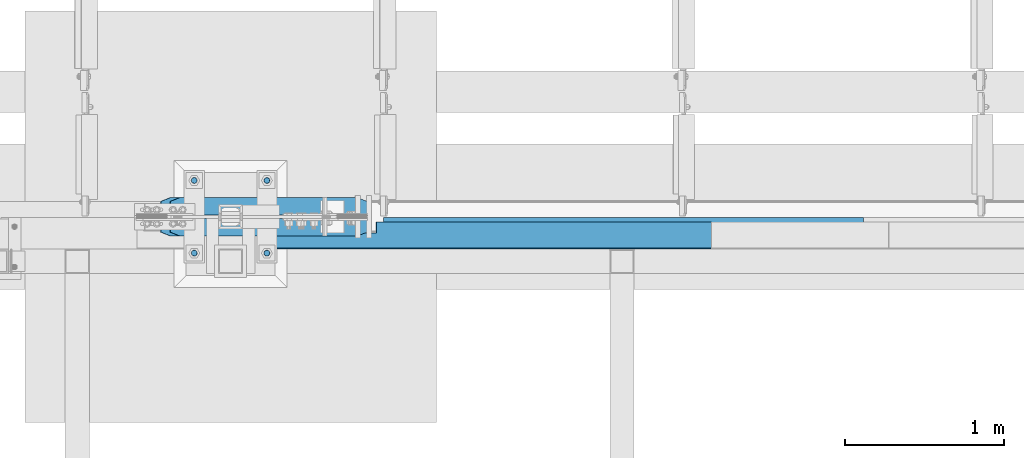
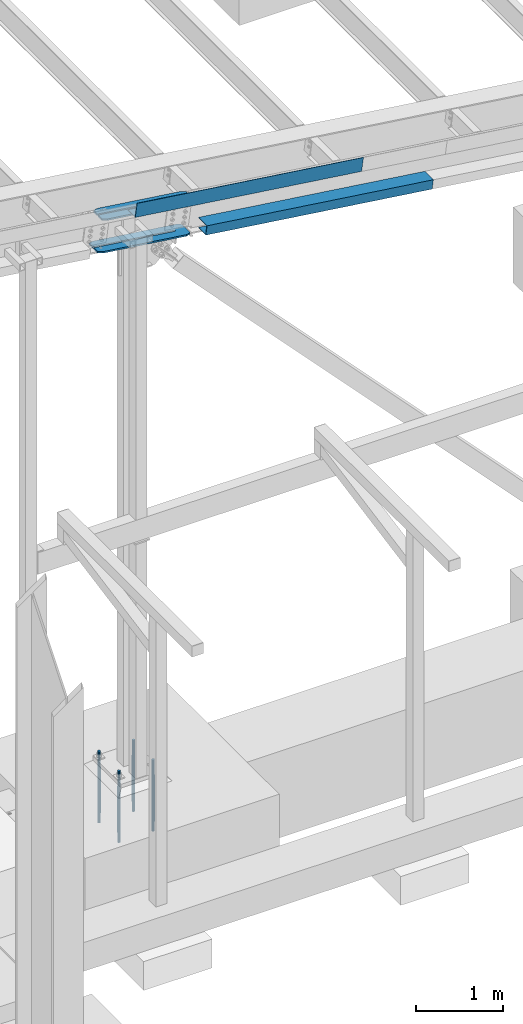
# One storey, part 744 of 1179: 8 beams, 3 elements without a shape of their own.
"""IFC2X3 building model written with IfcOpenShell, lengths in millimetres."""

from ifc_helpers import new_model, si_unit, frame, origin_with_axes, place, context, subcontext, project, spatial, faceted_brep, material, type_object, element, aggregate, save


model = new_model("IFC2X3")

# Units and contexts
model_context = context("Model", 3, precision=1e-05, world=origin_with_axes())
body_context = subcontext(model_context, "Body", "Model", "MODEL_VIEW")
ifc_project = project(units=[si_unit("LENGTHUNIT", "METRE", prefix="MILLI"), si_unit("AREAUNIT", "SQUARE_METRE"), si_unit("VOLUMEUNIT", "CUBIC_METRE"), si_unit("MASSUNIT", "GRAM", prefix="KILO"), si_unit("TIMEUNIT", "SECOND"), si_unit("PLANEANGLEUNIT", "RADIAN"), si_unit("SOLIDANGLEUNIT", "STERADIAN"), si_unit("THERMODYNAMICTEMPERATUREUNIT", "DEGREE_CELSIUS"), si_unit("LUMINOUSINTENSITYUNIT", "LUMEN")], contexts=[model_context])

# Site, building, storey
site_placement = place(None, origin_with_axes())
site = spatial("IfcSite", under=ifc_project, at=site_placement, CompositionType="ELEMENT")
building_placement = place(site_placement, origin_with_axes())
building = spatial("IfcBuilding", under=site, at=building_placement, Name="Undefined", CompositionType="ELEMENT")
storey_placement = place(building_placement, origin_with_axes())
storey = spatial("IfcBuildingStorey", under=building, at=storey_placement, Name="Undefined", CompositionType="ELEMENT", Elevation=0.0)

# Assembly, beams
assembly_1_placement = place(storey_placement, origin_with_axes())
assembly_1 = element("IfcElementAssembly", 1, at=assembly_1_placement, inside=storey, Name="BEAM", AssemblyPlace="NOTDEFINED", PredefinedType="RIGID_FRAME")
ifc_material_1 = material(Name="STEEL/A36")
beam_type_1 = type_object("IfcBeamType", PredefinedType="NOTDEFINED")
beam_1_placement = place(assembly_1_placement, frame((29302.4965897463, 4448.17500000529, 7554.44310047131), z_axis=(0.99100656965293, 0.0, -0.133813223953134), x_axis=(-0.133813222971046, 0.0, -0.991006569785539)))
beam_1 = element("IfcBeam", 2, at=beam_1_placement, type_object=beam_type_1, material=ifc_material_1, Name="BENT_PLATE", context=body_context, shape_type="Brep", body=[
    faceted_brep([(190.499999995369, 166.687500010301, -703.547262437609), (184.149999995367, 166.687500010301, -703.547262437613), (184.149999995199, 96.8374997306582, -703.547262437052), (190.499999995202, 96.8374997306582, -703.547262437067), (190.4999999953, 96.8374997503342, -603.862211291878), (184.149999995298, 96.8374997503342, -603.862211291867), (184.149999995439, 166.687500010349, -603.862211292424), (190.499999995443, 166.687500010349, -603.862211292424), (0.0, -3.17499999999927, -1524.0), (6.00266503170133e-10, -3.17499999922438, 1524.00000000052), (6.00266503170133e-10, 3.17500000077416, 1524.00000000052), (0.0, 3.17499999999927, -1524.0), (184.149999997837, 3.17500000000018, 1524.00000000004), (184.149999993959, 3.17500000000018, -1524.00000000062), (190.499999993961, -3.17500000000018, -1524.00000000063), (184.149999994715, 166.687499981327, -1524.00000000071), (190.499999994716, 166.687499981327, -1524.00000000072), (190.499999997839, -3.17500000000018, 1524.00000000003), (190.499999997002, 166.687500011378, 1523.99999999994), (184.149999997, 166.687500011378, 1523.99999999996)], [[[0, 1, 2, 3]], [[4, 5, 6, 7]], [[3, 2, 5, 4]], [[8, 9, 10, 11]], [[11, 10, 12, 13]], [[14, 8, 11, 13, 15, 16]], [[9, 8, 14, 17]], [[12, 10, 9, 17, 18, 19]], [[19, 18, 7, 6]], [[1, 15, 13, 12, 19, 6, 5, 2]], [[16, 15, 1, 0]], [[18, 17, 14, 16, 0, 3, 4, 7]]]),
])
beam_type_2 = type_object("IfcBeamType", PredefinedType="NOTDEFINED")
beam_2_placement = place(assembly_1_placement, frame((30235.061825248, 4642.64374999283, 6909.50331876021), z_axis=(-0.99100656978554, 0.0, 0.133813222971043), x_axis=(0.0, -1.0, 0.0)))
beam_2 = element("IfcBeam", 3, at=beam_2_placement, type_object=beam_type_2, material=ifc_material_1, Name="BENT_PLATE", context=body_context, shape_type="Brep", body=[
    faceted_brep([(0.0, -3.17499999999927, -1524.0), (6.00266503170133e-10, -3.17499999922438, 1524.00000000052), (6.00266503170133e-10, 3.17500000077416, 1524.00000000052), (0.0, 3.17499999999927, -1524.0), (197.643749996568, 3.17499999764368, 1524.00000000029), (197.64374999733, 3.17499999680149, -1524.00000000037), (191.29374999733, -3.17500000311156, -1524.00000000037), (191.293749996567, -3.17500000226937, 1524.0000000003), (197.643749997295, -123.825000009543, 1524.00000000049), (197.643749996602, -123.825000012654, -1524.00000000017), (191.293749996602, -117.47500001367, -1524.00000000018), (191.293749997295, -117.47500001056, 1524.00000000048), (27.7812499864749, -123.825000037206, 1524.00000000058), (27.7812499848405, -123.825000039436, -1524.00000000008), (27.7812499854572, -117.475000037206, 1524.00000000057), (27.7812499838228, -117.475000039432, -1524.00000000009)], [[[0, 1, 2, 3]], [[3, 2, 4, 5]], [[1, 0, 6, 7]], [[5, 4, 8, 9]], [[7, 6, 10, 11]], [[9, 8, 12, 13]], [[8, 4, 2, 1, 7, 11, 14, 12]], [[11, 10, 15, 14]], [[10, 6, 0, 3, 5, 9, 13, 15]], [[14, 15, 13, 12]]]),
])
aggregate(assembly_1, [beam_1, beam_2])

assembly_2_placement = place(storey_placement, origin_with_axes())
assembly_2 = element("IfcElementAssembly", 4, at=assembly_2_placement, inside=storey, Name="COLUMN", AssemblyPlace="NOTDEFINED", PredefinedType="RIGID_FRAME")
ifc_material_2 = material(Name="STEEL/A572-GR.50")
beam_type_3 = type_object("IfcBeamType", PredefinedType="NOTDEFINED")
beam_3_placement = place(assembly_2_placement, frame((27322.974220071, 4648.2000010376, 7169.75722502091), z_axis=(0.0, -1.0, 0.0), x_axis=(0.99100656965293, 0.0, -0.133813223953134)))
beam_3 = element("IfcBeam", 5, at=beam_3_placement, type_object=beam_type_3, material=ifc_material_2, Name="PLATE", context=body_context, shape_type="Brep", body=[
    faceted_brep([(63.5000000000036, -11.1125000000211, -122.2375), (-1.09139364212751e-11, -11.1125000000029, -96.8374999999996), (1.81898940354586e-11, 11.1125000000047, -96.8374999999996), (63.5000000000291, 11.1124999999884, -122.2375), (63.5000000000291, 11.1124999999884, 122.2375), (1.81898940354586e-11, 11.1125000000047, 96.8374999999996), (-1.09139364212751e-11, -11.1125000000029, 96.8374999999996), (63.5000000000036, -11.1125000000211, 122.2375), (1247.75782309306, -11.1125000003485, -96.8374999999996), (1184.25782309304, -11.1125000003303, -122.2375), (1184.25782309307, 11.1124999996773, -122.2375), (1247.75782309308, 11.1124999996609, -96.8374999999996), (1247.75782309308, 11.1124999996609, 96.8374999999996), (1184.25782309307, 11.1124999996773, 122.2375), (1184.25782309304, -11.1125000003303, 122.2375), (1247.75782309306, -11.1125000003485, 96.8374999999996), (-1.09139364212751e-11, -11.1125000000029, 11.1125010375927), (1.81898940354586e-11, 11.1125000000047, 11.1125010375927), (1093.77032170487, 11.1124999997028, 11.1125010375927), (1093.77018739046, -11.1125000003049, 11.1125010375927), (1098.02289142009, 11.112499999701, 10.2666123281051), (1098.02275710569, -11.1125000003067, 10.2666123281051), (1101.62804594581, 11.112499999701, 7.85772508766331), (1101.62791163141, -11.1125000003085, 7.85772508766331), (1104.0369331863, 11.112499999701, 4.25257056200553), (1104.0367988719, -11.1125000003085, 4.25257056200553), (1093.77018739046, -11.1125000003049, -11.1124989624059), (1093.77032170487, 11.1124999997028, -11.1124989624059), (1.81898940354586e-11, 11.1125000000047, -11.1124989624059), (-1.09139364212751e-11, -11.1125000000029, -11.1124989624059), (1098.02275710569, -11.1125000003067, -10.2666102529183), (1098.02289142009, 11.112499999701, -10.2666102529183), (1101.62791163141, -11.1125000003085, -7.85772301247653), (1101.62804594581, 11.112499999701, -7.85772301247653), (1104.0367988719, -11.1125000003085, -4.25256848681875), (1104.0369331863, 11.112499999701, -4.25256848681875), (1104.8826875814, -11.1125000003085, 8.46857801661827e-07), (1104.8828218958, 11.1124999996991, 8.46857801661827e-07)], [[[0, 1, 2, 3]], [[4, 5, 6, 7]], [[8, 9, 10, 11]], [[12, 13, 14, 15]], [[16, 17, 18, 19]], [[19, 18, 20, 21]], [[21, 20, 22, 23]], [[23, 22, 24, 25]], [[26, 27, 28, 29]], [[30, 31, 27, 26]], [[32, 33, 31, 30]], [[34, 35, 33, 32]], [[36, 37, 35, 34]], [[25, 24, 37, 36]], [[14, 13, 4, 7]], [[12, 15, 8, 11]], [[10, 9, 0, 3]], [[29, 28, 2, 1]], [[28, 27, 31, 33, 35, 37, 24, 22, 20, 18, 17, 5, 4, 13, 12, 11, 10, 3, 2]], [[17, 16, 6, 5]], [[9, 8, 15, 14, 7, 6, 16, 19, 21, 23, 25, 36, 34, 32, 30, 26, 29, 1, 0]]]),
])
beam_4_placement = place(assembly_2_placement, frame((27382.4541981187, 4648.2000010376, 7610.25964523436), z_axis=(0.0, -1.0, 0.0), x_axis=(0.99100656965293, 0.0, -0.133813223953134)))
beam_4 = element("IfcBeam", 6, at=beam_4_placement, type_object=beam_type_3, material=ifc_material_2, Name="PLATE", context=body_context, shape_type="Brep", body=[
    faceted_brep([(63.5000000000036, -11.1125000000211, -122.2375), (-1.09139364212751e-11, -11.1125000000029, -96.8374999999996), (1.81898940354586e-11, 11.1125000000047, -96.8374999999996), (63.5000000000291, 11.1124999999884, -122.2375), (63.5000000000291, 11.1124999999884, 122.2375), (1.81898940354586e-11, 11.1125000000047, 96.8374999999996), (-1.09139364212751e-11, -11.1125000000029, 96.8374999999996), (63.5000000000036, -11.1125000000211, 122.2375), (1247.75782309306, -11.1125000003485, -96.8374999999996), (1184.25782309304, -11.1125000003303, -122.2375), (1184.25782309307, 11.1124999996773, -122.2375), (1247.75782309308, 11.1124999996609, -96.8374999999996), (1247.75782309308, 11.1124999996609, 96.8374999999996), (1184.25782309307, 11.1124999996773, 122.2375), (1184.25782309304, -11.1125000003303, 122.2375), (1247.75782309306, -11.1125000003485, 96.8374999999996), (-1.09139364212751e-11, -11.1125000000029, 11.1125010375927), (1.81898940354586e-11, 11.1125000000047, 11.1125010375927), (1093.77032170487, 11.1124999997028, 11.1125010375927), (1093.77018739046, -11.1125000003049, 11.1125010375927), (1098.02289142009, 11.112499999701, 10.2666123281051), (1098.02275710569, -11.1125000003067, 10.2666123281051), (1101.62804594581, 11.112499999701, 7.85772508766331), (1101.62791163141, -11.1125000003085, 7.85772508766331), (1104.0369331863, 11.112499999701, 4.25257056200553), (1104.0367988719, -11.1125000003085, 4.25257056200553), (1093.77018739046, -11.1125000003049, -11.1124989624059), (1093.77032170487, 11.1124999997028, -11.1124989624059), (1.81898940354586e-11, 11.1125000000047, -11.1124989624059), (-1.09139364212751e-11, -11.1125000000029, -11.1124989624059), (1098.02275710569, -11.1125000003067, -10.2666102529183), (1098.02289142009, 11.112499999701, -10.2666102529183), (1101.62791163141, -11.1125000003085, -7.85772301247653), (1101.62804594581, 11.112499999701, -7.85772301247653), (1104.0367988719, -11.1125000003085, -4.25256848681875), (1104.0369331863, 11.112499999701, -4.25256848681875), (1104.8826875814, -11.1125000003085, 8.46857801661827e-07), (1104.8828218958, 11.1124999996991, 8.46857801661827e-07)], [[[0, 1, 2, 3]], [[4, 5, 6, 7]], [[8, 9, 10, 11]], [[12, 13, 14, 15]], [[16, 17, 18, 19]], [[19, 18, 20, 21]], [[21, 20, 22, 23]], [[23, 22, 24, 25]], [[26, 27, 28, 29]], [[30, 31, 27, 26]], [[32, 33, 31, 30]], [[34, 35, 33, 32]], [[36, 37, 35, 34]], [[25, 24, 37, 36]], [[14, 13, 4, 7]], [[12, 15, 8, 11]], [[10, 9, 0, 3]], [[29, 28, 2, 1]], [[28, 27, 31, 33, 35, 37, 24, 22, 20, 18, 17, 5, 4, 13, 12, 11, 10, 3, 2]], [[17, 16, 6, 5]], [[9, 8, 15, 14, 7, 6, 16, 19, 21, 23, 25, 36, 34, 32, 30, 26, 29, 1, 0]]]),
])
aggregate(assembly_2, [beam_3, beam_4])

assembly_3_placement = place(storey_placement, origin_with_axes())
assembly_3 = element("IfcElementAssembly", 7, at=assembly_3_placement, inside=storey, Name="TEMPLATE", AssemblyPlace="NOTDEFINED", PredefinedType="RIGID_FRAME")
ifc_material_3 = material(Name="STEEL/F1554-GR.55")
beam_type_4 = type_object("IfcBeamType", PredefinedType="NOTDEFINED")
beam_5_placement = place(assembly_3_placement, frame((27533.6, 4876.79999389648, -355.599999999998), z_axis=(0.0, -1.0, 0.0), x_axis=(0.0, 0.0, -1.0)))
beam_5 = element("IfcBeam", 8, at=beam_5_placement, type_object=beam_type_4, material=ifc_material_3, Name="ANCHOR_ROD", context=body_context, shape_type="Brep", body=[
    faceted_brep([(-219.074999999997, -15.8101597714922, 9.1279999999997), (-219.074999999997, -9.12800000000425, 15.8101597714885), (-219.074999999997, -3.63797880709171e-12, 18.2560000000003), (-219.074999999997, 9.12799999999697, 15.8101597714885), (-219.074999999997, 15.8101597714849, 9.1279999999997), (-219.074999999997, 18.2559999999976, 0.0), (-219.074999999997, 15.8101597714849, -9.1279999999997), (-219.074999999997, 9.12799999999697, -15.8101597714885), (-219.074999999997, -3.63797880709171e-12, -18.2560000000003), (-219.074999999997, -9.12800000000425, -15.8101597714885), (-219.074999999997, -15.8101597714922, -9.1279999999997), (-219.074999999997, -18.2560000000049, 0.0), (2.27373675443232e-12, 18.2559999999976, 0.0), (2.27373675443232e-12, 15.8101597714849, -9.1279999999997), (2.27373675443232e-12, 9.12799999999697, -15.8101597714885), (2.27373675443232e-12, -3.63797880709171e-12, -18.2560000000003), (2.27373675443232e-12, -9.12800000000425, -15.8101597714885), (2.27373675443232e-12, -15.8101597714922, -9.1279999999997), (2.27373675443232e-12, -18.2560000000049, 0.0), (2.27373675443232e-12, -15.8101597714922, 9.1279999999997), (2.27373675443232e-12, -9.12800000000425, 15.8101597714885), (2.27373675443232e-12, -3.63797880709171e-12, 18.2560000000003), (2.27373675443232e-12, 9.12799999999697, 15.8101597714885), (2.27373675443232e-12, 15.8101597714849, 9.1279999999997), (-5.0931703299284e-11, -16.4977839420935, 9.52500000000146), (-6.54836185276508e-11, -9.52499999999964, 16.4977839420935), (-6.54836185276508e-11, 0.0, 19.0499999999993), (-4.36557456851006e-11, 9.52499999999964, 16.4977839420935), (-1.45519152283669e-11, 16.4977839420935, 9.52500000000146), (2.18278728425503e-11, 19.0499999999993, 0.0), (5.0931703299284e-11, 16.4977839420935, -9.52500000000146), (6.54836185276508e-11, 9.52499999999964, -16.4977839420935), (6.54836185276508e-11, 0.0, -19.0499999999993), (4.36557456851006e-11, -9.52499999999964, -16.4977839420935), (1.45519152283669e-11, -16.4977839420935, -9.52500000000146), (-2.18278728425503e-11, -19.0499999999993, 0.0), (654.050000000003, -19.0499999999993, 0.0), (654.050000000003, -16.4977839420935, 9.52499999999964), (654.050000000003, -9.52500000000146, 16.4977839420935), (654.050000000003, 0.0, 19.0500000000002), (654.050000000003, 9.52500000000146, 16.4977839420935), (654.050000000003, 16.4977839420935, 9.52499999999964), (654.050000000003, 19.0499999999993, 0.0), (654.050000000003, 16.4977839420935, -9.52499999999964), (654.050000000003, 9.52500000000146, -16.4977839420935), (654.050000000003, 0.0, -19.0500000000002), (654.050000000003, -9.52500000000146, -16.4977839420935), (654.050000000003, -16.4977839420935, -9.52499999999964), (654.050000000003, -9.12799999999697, 15.8101597714885), (654.050000000003, 3.63797880709171e-12, 18.2560000000003), (654.050000000003, 9.12800000000425, 15.8101597714885), (654.050000000003, 15.8101597714922, 9.1279999999997), (654.050000000003, 18.2560000000049, 0.0), (654.050000000003, 15.8101597714922, -9.1279999999997), (654.050000000003, 9.12800000000425, -15.8101597714885), (654.050000000003, 3.63797880709171e-12, -18.2560000000003), (654.050000000003, -9.12799999999697, -15.8101597714885), (654.050000000003, -15.8101597714849, -9.1279999999997), (654.050000000003, -18.2559999999976, 0.0), (654.050000000003, -15.8101597714849, 9.1279999999997), (787.400000000002, -9.12799999999697, -15.8101597714885), (787.400000000002, 3.63797880709171e-12, -18.2560000000003), (787.400000000002, 9.12800000000425, -15.8101597714885), (787.400000000002, 15.8101597714922, -9.1279999999997), (787.400000000002, 18.2560000000049, 0.0), (787.400000000002, 15.8101597714922, 9.1279999999997), (787.400000000002, 9.12800000000425, 15.8101597714885), (787.400000000002, 3.63797880709171e-12, 18.2560000000003), (787.400000000002, -9.12799999999697, 15.8101597714885), (787.400000000002, -15.8101597714849, 9.1279999999997), (787.400000000002, -18.2559999999976, 0.0), (787.400000000002, -15.8101597714849, -9.1279999999997)], [[[0, 1, 2, 3, 4, 5, 6, 7, 8, 9, 10, 11]], [[6, 5, 12, 13]], [[7, 6, 13, 14]], [[8, 7, 14, 15]], [[9, 8, 15, 16]], [[10, 9, 16, 17]], [[11, 10, 17, 18]], [[0, 11, 18, 19]], [[1, 0, 19, 20]], [[2, 1, 20, 21]], [[3, 2, 21, 22]], [[4, 3, 22, 23]], [[5, 4, 23, 12]], [[24, 25, 26, 27, 28, 29, 30, 31, 32, 33, 34, 35], [22, 21, 20, 19, 18, 17, 16, 15, 14, 13, 12, 23]], [[24, 35, 36, 37]], [[25, 24, 37, 38]], [[26, 25, 38, 39]], [[27, 26, 39, 40]], [[28, 27, 40, 41]], [[29, 28, 41, 42]], [[30, 29, 42, 43]], [[31, 30, 43, 44]], [[32, 31, 44, 45]], [[33, 32, 45, 46]], [[34, 33, 46, 47]], [[35, 34, 47, 36]], [[46, 45, 44, 43, 42, 41, 40, 39, 38, 37, 36, 47], [48, 49, 50, 51, 52, 53, 54, 55, 56, 57, 58, 59]], [[60, 61, 62, 63, 64, 65, 66, 67, 68, 69, 70, 71]], [[68, 67, 49, 48]], [[69, 68, 48, 59]], [[70, 69, 59, 58]], [[71, 70, 58, 57]], [[60, 71, 57, 56]], [[61, 60, 56, 55]], [[62, 61, 55, 54]], [[63, 62, 54, 53]], [[64, 63, 53, 52]], [[65, 64, 52, 51]], [[66, 65, 51, 50]], [[67, 66, 50, 49]]]),
])
beam_6_placement = place(assembly_3_placement, frame((27533.6, 4419.59999389648, -355.599999999999), z_axis=(0.0, -1.0, 0.0), x_axis=(0.0, 0.0, -1.0)))
beam_6 = element("IfcBeam", 9, at=beam_6_placement, type_object=beam_type_4, material=ifc_material_3, Name="ANCHOR_ROD", context=body_context, shape_type="Brep", body=[
    faceted_brep([(-219.074999999997, -15.8101597714922, 9.1279999999997), (-219.074999999997, -9.12800000000425, 15.8101597714885), (-219.074999999997, -3.63797880709171e-12, 18.2560000000003), (-219.074999999997, 9.12799999999697, 15.8101597714885), (-219.074999999997, 15.8101597714849, 9.1279999999997), (-219.074999999997, 18.2559999999976, 0.0), (-219.074999999997, 15.8101597714849, -9.1279999999997), (-219.074999999997, 9.12799999999697, -15.8101597714885), (-219.074999999997, -3.63797880709171e-12, -18.2560000000003), (-219.074999999997, -9.12800000000425, -15.8101597714885), (-219.074999999997, -15.8101597714922, -9.1279999999997), (-219.074999999997, -18.2560000000049, 0.0), (2.27373675443232e-12, 18.2559999999976, 0.0), (2.27373675443232e-12, 15.8101597714849, -9.1279999999997), (2.27373675443232e-12, 9.12799999999697, -15.8101597714885), (2.27373675443232e-12, -3.63797880709171e-12, -18.2560000000003), (2.27373675443232e-12, -9.12800000000425, -15.8101597714885), (2.27373675443232e-12, -15.8101597714922, -9.1279999999997), (2.27373675443232e-12, -18.2560000000049, 0.0), (2.27373675443232e-12, -15.8101597714922, 9.1279999999997), (2.27373675443232e-12, -9.12800000000425, 15.8101597714885), (2.27373675443232e-12, -3.63797880709171e-12, 18.2560000000003), (2.27373675443232e-12, 9.12799999999697, 15.8101597714885), (2.27373675443232e-12, 15.8101597714849, 9.1279999999997), (-5.0931703299284e-11, -16.4977839420935, 9.52500000000146), (-6.54836185276508e-11, -9.52499999999964, 16.4977839420935), (-6.54836185276508e-11, 0.0, 19.0499999999993), (-4.36557456851006e-11, 9.52499999999964, 16.4977839420935), (-1.45519152283669e-11, 16.4977839420935, 9.52500000000146), (2.18278728425503e-11, 19.0499999999993, 0.0), (5.0931703299284e-11, 16.4977839420935, -9.52500000000146), (6.54836185276508e-11, 9.52499999999964, -16.4977839420935), (6.54836185276508e-11, 0.0, -19.0499999999993), (4.36557456851006e-11, -9.52499999999964, -16.4977839420935), (1.45519152283669e-11, -16.4977839420935, -9.52500000000146), (-2.18278728425503e-11, -19.0499999999993, 0.0), (654.050000000003, -19.0499999999993, 0.0), (654.050000000003, -16.4977839420935, 9.52499999999964), (654.050000000003, -9.52500000000146, 16.4977839420935), (654.050000000003, 0.0, 19.0500000000002), (654.050000000003, 9.52500000000146, 16.4977839420935), (654.050000000003, 16.4977839420935, 9.52499999999964), (654.050000000003, 19.0499999999993, 0.0), (654.050000000003, 16.4977839420935, -9.52499999999964), (654.050000000003, 9.52500000000146, -16.4977839420935), (654.050000000003, 0.0, -19.0500000000002), (654.050000000003, -9.52500000000146, -16.4977839420935), (654.050000000003, -16.4977839420935, -9.52499999999964), (654.050000000003, -9.12799999999697, 15.8101597714885), (654.050000000003, 3.63797880709171e-12, 18.2560000000003), (654.050000000003, 9.12800000000425, 15.8101597714885), (654.050000000003, 15.8101597714922, 9.1279999999997), (654.050000000003, 18.2560000000049, 0.0), (654.050000000003, 15.8101597714922, -9.1279999999997), (654.050000000003, 9.12800000000425, -15.8101597714885), (654.050000000003, 3.63797880709171e-12, -18.2560000000003), (654.050000000003, -9.12799999999697, -15.8101597714885), (654.050000000003, -15.8101597714849, -9.1279999999997), (654.050000000003, -18.2559999999976, 0.0), (654.050000000003, -15.8101597714849, 9.1279999999997), (787.400000000002, -9.12799999999697, -15.8101597714885), (787.400000000002, 3.63797880709171e-12, -18.2560000000003), (787.400000000002, 9.12800000000425, -15.8101597714885), (787.400000000002, 15.8101597714922, -9.1279999999997), (787.400000000002, 18.2560000000049, 0.0), (787.400000000002, 15.8101597714922, 9.1279999999997), (787.400000000002, 9.12800000000425, 15.8101597714885), (787.400000000002, 3.63797880709171e-12, 18.2560000000003), (787.400000000002, -9.12799999999697, 15.8101597714885), (787.400000000002, -15.8101597714849, 9.1279999999997), (787.400000000002, -18.2559999999976, 0.0), (787.400000000002, -15.8101597714849, -9.1279999999997)], [[[0, 1, 2, 3, 4, 5, 6, 7, 8, 9, 10, 11]], [[6, 5, 12, 13]], [[7, 6, 13, 14]], [[8, 7, 14, 15]], [[9, 8, 15, 16]], [[10, 9, 16, 17]], [[11, 10, 17, 18]], [[0, 11, 18, 19]], [[1, 0, 19, 20]], [[2, 1, 20, 21]], [[3, 2, 21, 22]], [[4, 3, 22, 23]], [[5, 4, 23, 12]], [[24, 25, 26, 27, 28, 29, 30, 31, 32, 33, 34, 35], [22, 21, 20, 19, 18, 17, 16, 15, 14, 13, 12, 23]], [[24, 35, 36, 37]], [[25, 24, 37, 38]], [[26, 25, 38, 39]], [[27, 26, 39, 40]], [[28, 27, 40, 41]], [[29, 28, 41, 42]], [[30, 29, 42, 43]], [[31, 30, 43, 44]], [[32, 31, 44, 45]], [[33, 32, 45, 46]], [[34, 33, 46, 47]], [[35, 34, 47, 36]], [[46, 45, 44, 43, 42, 41, 40, 39, 38, 37, 36, 47], [48, 49, 50, 51, 52, 53, 54, 55, 56, 57, 58, 59]], [[60, 61, 62, 63, 64, 65, 66, 67, 68, 69, 70, 71]], [[68, 67, 49, 48]], [[69, 68, 48, 59]], [[70, 69, 59, 58]], [[71, 70, 58, 57]], [[60, 71, 57, 56]], [[61, 60, 56, 55]], [[62, 61, 55, 54]], [[63, 62, 54, 53]], [[64, 63, 53, 52]], [[65, 64, 52, 51]], [[66, 65, 51, 50]], [[67, 66, 50, 49]]]),
])
beam_7_placement = place(assembly_3_placement, frame((27990.8, 4876.79999389648, -355.599999999998), z_axis=(0.0, 1.0, 0.0), x_axis=(0.0, 0.0, -1.0)))
beam_7 = element("IfcBeam", 10, at=beam_7_placement, type_object=beam_type_4, material=ifc_material_3, Name="ANCHOR_ROD", context=body_context, shape_type="Brep", body=[
    faceted_brep([(-219.074999999997, -15.8101597714922, 9.1279999999997), (-219.074999999997, -9.12800000000425, 15.8101597714885), (-219.074999999997, -3.63797880709171e-12, 18.2560000000003), (-219.074999999997, 9.12799999999697, 15.8101597714885), (-219.074999999997, 15.8101597714849, 9.1279999999997), (-219.074999999997, 18.2559999999976, 0.0), (-219.074999999997, 15.8101597714849, -9.1279999999997), (-219.074999999997, 9.12799999999697, -15.8101597714885), (-219.074999999997, -3.63797880709171e-12, -18.2560000000003), (-219.074999999997, -9.12800000000425, -15.8101597714885), (-219.074999999997, -15.8101597714922, -9.1279999999997), (-219.074999999997, -18.2560000000049, 0.0), (2.27373675443232e-12, 18.2559999999976, 0.0), (2.27373675443232e-12, 15.8101597714849, -9.1279999999997), (2.27373675443232e-12, 9.12799999999697, -15.8101597714885), (2.27373675443232e-12, -3.63797880709171e-12, -18.2560000000003), (2.27373675443232e-12, -9.12800000000425, -15.8101597714885), (2.27373675443232e-12, -15.8101597714922, -9.1279999999997), (2.27373675443232e-12, -18.2560000000049, 0.0), (2.27373675443232e-12, -15.8101597714922, 9.1279999999997), (2.27373675443232e-12, -9.12800000000425, 15.8101597714885), (2.27373675443232e-12, -3.63797880709171e-12, 18.2560000000003), (2.27373675443232e-12, 9.12799999999697, 15.8101597714885), (2.27373675443232e-12, 15.8101597714849, 9.1279999999997), (-5.0931703299284e-11, -16.4977839420935, 9.52500000000146), (-6.54836185276508e-11, -9.52499999999964, 16.4977839420935), (-6.54836185276508e-11, 0.0, 19.0499999999993), (-4.36557456851006e-11, 9.52499999999964, 16.4977839420935), (-1.45519152283669e-11, 16.4977839420935, 9.52500000000146), (2.18278728425503e-11, 19.0499999999993, 0.0), (5.0931703299284e-11, 16.4977839420935, -9.52500000000146), (6.54836185276508e-11, 9.52499999999964, -16.4977839420935), (6.54836185276508e-11, 0.0, -19.0499999999993), (4.36557456851006e-11, -9.52499999999964, -16.4977839420935), (1.45519152283669e-11, -16.4977839420935, -9.52500000000146), (-2.18278728425503e-11, -19.0499999999993, 0.0), (654.050000000003, -19.0499999999993, 0.0), (654.050000000003, -16.4977839420935, 9.52499999999964), (654.050000000003, -9.52500000000146, 16.4977839420935), (654.050000000003, 0.0, 19.0500000000002), (654.050000000003, 9.52500000000146, 16.4977839420935), (654.050000000003, 16.4977839420935, 9.52499999999964), (654.050000000003, 19.0499999999993, 0.0), (654.050000000003, 16.4977839420935, -9.52499999999964), (654.050000000003, 9.52500000000146, -16.4977839420935), (654.050000000003, 0.0, -19.0500000000002), (654.050000000003, -9.52500000000146, -16.4977839420935), (654.050000000003, -16.4977839420935, -9.52499999999964), (654.050000000003, -9.12799999999697, 15.8101597714885), (654.050000000003, 3.63797880709171e-12, 18.2560000000003), (654.050000000003, 9.12800000000425, 15.8101597714885), (654.050000000003, 15.8101597714922, 9.1279999999997), (654.050000000003, 18.2560000000049, 0.0), (654.050000000003, 15.8101597714922, -9.1279999999997), (654.050000000003, 9.12800000000425, -15.8101597714885), (654.050000000003, 3.63797880709171e-12, -18.2560000000003), (654.050000000003, -9.12799999999697, -15.8101597714885), (654.050000000003, -15.8101597714849, -9.1279999999997), (654.050000000003, -18.2559999999976, 0.0), (654.050000000003, -15.8101597714849, 9.1279999999997), (787.400000000002, -9.12799999999697, -15.8101597714885), (787.400000000002, 3.63797880709171e-12, -18.2560000000003), (787.400000000002, 9.12800000000425, -15.8101597714885), (787.400000000002, 15.8101597714922, -9.1279999999997), (787.400000000002, 18.2560000000049, 0.0), (787.400000000002, 15.8101597714922, 9.1279999999997), (787.400000000002, 9.12800000000425, 15.8101597714885), (787.400000000002, 3.63797880709171e-12, 18.2560000000003), (787.400000000002, -9.12799999999697, 15.8101597714885), (787.400000000002, -15.8101597714849, 9.1279999999997), (787.400000000002, -18.2559999999976, 0.0), (787.400000000002, -15.8101597714849, -9.1279999999997)], [[[0, 1, 2, 3, 4, 5, 6, 7, 8, 9, 10, 11]], [[6, 5, 12, 13]], [[7, 6, 13, 14]], [[8, 7, 14, 15]], [[9, 8, 15, 16]], [[10, 9, 16, 17]], [[11, 10, 17, 18]], [[0, 11, 18, 19]], [[1, 0, 19, 20]], [[2, 1, 20, 21]], [[3, 2, 21, 22]], [[4, 3, 22, 23]], [[5, 4, 23, 12]], [[24, 25, 26, 27, 28, 29, 30, 31, 32, 33, 34, 35], [22, 21, 20, 19, 18, 17, 16, 15, 14, 13, 12, 23]], [[24, 35, 36, 37]], [[25, 24, 37, 38]], [[26, 25, 38, 39]], [[27, 26, 39, 40]], [[28, 27, 40, 41]], [[29, 28, 41, 42]], [[30, 29, 42, 43]], [[31, 30, 43, 44]], [[32, 31, 44, 45]], [[33, 32, 45, 46]], [[34, 33, 46, 47]], [[35, 34, 47, 36]], [[46, 45, 44, 43, 42, 41, 40, 39, 38, 37, 36, 47], [48, 49, 50, 51, 52, 53, 54, 55, 56, 57, 58, 59]], [[60, 61, 62, 63, 64, 65, 66, 67, 68, 69, 70, 71]], [[68, 67, 49, 48]], [[69, 68, 48, 59]], [[70, 69, 59, 58]], [[71, 70, 58, 57]], [[60, 71, 57, 56]], [[61, 60, 56, 55]], [[62, 61, 55, 54]], [[63, 62, 54, 53]], [[64, 63, 53, 52]], [[65, 64, 52, 51]], [[66, 65, 51, 50]], [[67, 66, 50, 49]]]),
])
beam_8_placement = place(assembly_3_placement, frame((27990.8, 4419.59999389648, -355.599999999999), z_axis=(0.0, 1.0, 0.0), x_axis=(0.0, 0.0, -1.0)))
beam_8 = element("IfcBeam", 11, at=beam_8_placement, type_object=beam_type_4, material=ifc_material_3, Name="ANCHOR_ROD", context=body_context, shape_type="Brep", body=[
    faceted_brep([(-219.074999999997, -15.8101597714922, 9.1279999999997), (-219.074999999997, -9.12800000000425, 15.8101597714885), (-219.074999999997, -3.63797880709171e-12, 18.2560000000003), (-219.074999999997, 9.12799999999697, 15.8101597714885), (-219.074999999997, 15.8101597714849, 9.1279999999997), (-219.074999999997, 18.2559999999976, 0.0), (-219.074999999997, 15.8101597714849, -9.1279999999997), (-219.074999999997, 9.12799999999697, -15.8101597714885), (-219.074999999997, -3.63797880709171e-12, -18.2560000000003), (-219.074999999997, -9.12800000000425, -15.8101597714885), (-219.074999999997, -15.8101597714922, -9.1279999999997), (-219.074999999997, -18.2560000000049, 0.0), (2.27373675443232e-12, 18.2559999999976, 0.0), (2.27373675443232e-12, 15.8101597714849, -9.1279999999997), (2.27373675443232e-12, 9.12799999999697, -15.8101597714885), (2.27373675443232e-12, -3.63797880709171e-12, -18.2560000000003), (2.27373675443232e-12, -9.12800000000425, -15.8101597714885), (2.27373675443232e-12, -15.8101597714922, -9.1279999999997), (2.27373675443232e-12, -18.2560000000049, 0.0), (2.27373675443232e-12, -15.8101597714922, 9.1279999999997), (2.27373675443232e-12, -9.12800000000425, 15.8101597714885), (2.27373675443232e-12, -3.63797880709171e-12, 18.2560000000003), (2.27373675443232e-12, 9.12799999999697, 15.8101597714885), (2.27373675443232e-12, 15.8101597714849, 9.1279999999997), (-5.0931703299284e-11, -16.4977839420935, 9.52500000000146), (-6.54836185276508e-11, -9.52499999999964, 16.4977839420935), (-6.54836185276508e-11, 0.0, 19.0499999999993), (-4.36557456851006e-11, 9.52499999999964, 16.4977839420935), (-1.45519152283669e-11, 16.4977839420935, 9.52500000000146), (2.18278728425503e-11, 19.0499999999993, 0.0), (5.0931703299284e-11, 16.4977839420935, -9.52500000000146), (6.54836185276508e-11, 9.52499999999964, -16.4977839420935), (6.54836185276508e-11, 0.0, -19.0499999999993), (4.36557456851006e-11, -9.52499999999964, -16.4977839420935), (1.45519152283669e-11, -16.4977839420935, -9.52500000000146), (-2.18278728425503e-11, -19.0499999999993, 0.0), (654.050000000003, -19.0499999999993, 0.0), (654.050000000003, -16.4977839420935, 9.52499999999964), (654.050000000003, -9.52500000000146, 16.4977839420935), (654.050000000003, 0.0, 19.0500000000002), (654.050000000003, 9.52500000000146, 16.4977839420935), (654.050000000003, 16.4977839420935, 9.52499999999964), (654.050000000003, 19.0499999999993, 0.0), (654.050000000003, 16.4977839420935, -9.52499999999964), (654.050000000003, 9.52500000000146, -16.4977839420935), (654.050000000003, 0.0, -19.0500000000002), (654.050000000003, -9.52500000000146, -16.4977839420935), (654.050000000003, -16.4977839420935, -9.52499999999964), (654.050000000003, -9.12799999999697, 15.8101597714885), (654.050000000003, 3.63797880709171e-12, 18.2560000000003), (654.050000000003, 9.12800000000425, 15.8101597714885), (654.050000000003, 15.8101597714922, 9.1279999999997), (654.050000000003, 18.2560000000049, 0.0), (654.050000000003, 15.8101597714922, -9.1279999999997), (654.050000000003, 9.12800000000425, -15.8101597714885), (654.050000000003, 3.63797880709171e-12, -18.2560000000003), (654.050000000003, -9.12799999999697, -15.8101597714885), (654.050000000003, -15.8101597714849, -9.1279999999997), (654.050000000003, -18.2559999999976, 0.0), (654.050000000003, -15.8101597714849, 9.1279999999997), (787.400000000002, -9.12799999999697, -15.8101597714885), (787.400000000002, 3.63797880709171e-12, -18.2560000000003), (787.400000000002, 9.12800000000425, -15.8101597714885), (787.400000000002, 15.8101597714922, -9.1279999999997), (787.400000000002, 18.2560000000049, 0.0), (787.400000000002, 15.8101597714922, 9.1279999999997), (787.400000000002, 9.12800000000425, 15.8101597714885), (787.400000000002, 3.63797880709171e-12, 18.2560000000003), (787.400000000002, -9.12799999999697, 15.8101597714885), (787.400000000002, -15.8101597714849, 9.1279999999997), (787.400000000002, -18.2559999999976, 0.0), (787.400000000002, -15.8101597714849, -9.1279999999997)], [[[0, 1, 2, 3, 4, 5, 6, 7, 8, 9, 10, 11]], [[6, 5, 12, 13]], [[7, 6, 13, 14]], [[8, 7, 14, 15]], [[9, 8, 15, 16]], [[10, 9, 16, 17]], [[11, 10, 17, 18]], [[0, 11, 18, 19]], [[1, 0, 19, 20]], [[2, 1, 20, 21]], [[3, 2, 21, 22]], [[4, 3, 22, 23]], [[5, 4, 23, 12]], [[24, 25, 26, 27, 28, 29, 30, 31, 32, 33, 34, 35], [22, 21, 20, 19, 18, 17, 16, 15, 14, 13, 12, 23]], [[24, 35, 36, 37]], [[25, 24, 37, 38]], [[26, 25, 38, 39]], [[27, 26, 39, 40]], [[28, 27, 40, 41]], [[29, 28, 41, 42]], [[30, 29, 42, 43]], [[31, 30, 43, 44]], [[32, 31, 44, 45]], [[33, 32, 45, 46]], [[34, 33, 46, 47]], [[35, 34, 47, 36]], [[46, 45, 44, 43, 42, 41, 40, 39, 38, 37, 36, 47], [48, 49, 50, 51, 52, 53, 54, 55, 56, 57, 58, 59]], [[60, 61, 62, 63, 64, 65, 66, 67, 68, 69, 70, 71]], [[68, 67, 49, 48]], [[69, 68, 48, 59]], [[70, 69, 59, 58]], [[71, 70, 58, 57]], [[60, 71, 57, 56]], [[61, 60, 56, 55]], [[62, 61, 55, 54]], [[63, 62, 54, 53]], [[64, 63, 53, 52]], [[65, 64, 52, 51]], [[66, 65, 51, 50]], [[67, 66, 50, 49]]]),
])
aggregate(assembly_3, [beam_5, beam_6, beam_7, beam_8])

save(model, "model.ifc")
